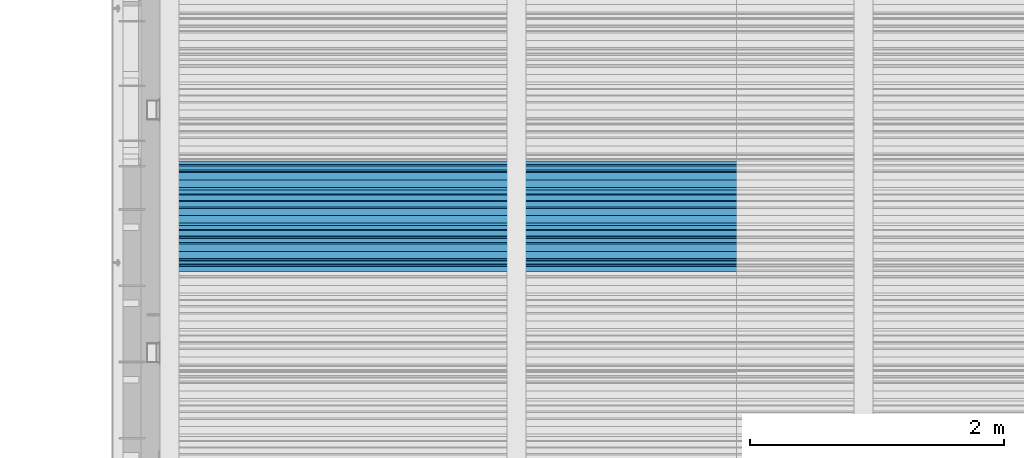
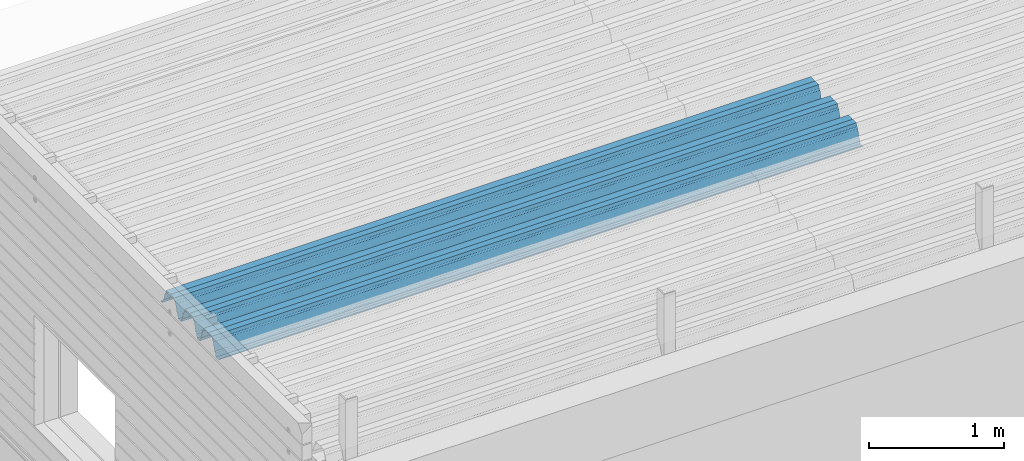
# One storey, part 27 of 153: 1 beam, 1 element without a shape of its own.
"""IFC2X3 building model written with IfcOpenShell, lengths in millimetres."""

from ifc_helpers import new_model, si_unit, frame, origin_with_axes, place, context, subcontext, project, spatial, faceted_brep, material, type_object, element, aggregate, save


model = new_model("IFC2X3")

# Units and contexts
model_context = context("Model", 3, precision=1e-05, world=origin_with_axes())
body_context = subcontext(model_context, "Body", "Model", "MODEL_VIEW")
ifc_project = project(units=[si_unit("LENGTHUNIT", "METRE", prefix="MILLI"), si_unit("AREAUNIT", "SQUARE_METRE"), si_unit("VOLUMEUNIT", "CUBIC_METRE"), si_unit("MASSUNIT", "GRAM", prefix="KILO"), si_unit("TIMEUNIT", "SECOND"), si_unit("PLANEANGLEUNIT", "RADIAN"), si_unit("SOLIDANGLEUNIT", "STERADIAN"), si_unit("THERMODYNAMICTEMPERATUREUNIT", "DEGREE_CELSIUS"), si_unit("LUMINOUSINTENSITYUNIT", "LUMEN")], contexts=[model_context])

# Site, building, storey
site_placement = place(None, origin_with_axes())
site = spatial("IfcSite", under=ifc_project, at=site_placement, CompositionType="ELEMENT")
building_placement = place(site_placement, origin_with_axes())
building = spatial("IfcBuilding", under=site, at=building_placement, CompositionType="ELEMENT")
storey_placement = place(building_placement, origin_with_axes())
storey = spatial("IfcBuildingStorey", under=building, at=storey_placement, Name="8", CompositionType="ELEMENT", Elevation=0.0)

# Assembly, beam
assembly_placement = place(storey_placement, origin_with_axes())
assembly = element("IfcElementAssembly", 1, at=assembly_placement, inside=storey, Name="Steel Assembly", AssemblyPlace="NOTDEFINED", PredefinedType="RIGID_FRAME")
ifc_material = material(Name="STEEL/S355J2")
beam_type = type_object("IfcBeamType", Name="W", PredefinedType="NOTDEFINED")
beam_placement = place(assembly_placement, frame((13534.9999999929, 17045.079381851, 105770.648873187), z_axis=(0.0, -0.0124990270013869, 0.999921884110963), x_axis=(-1.0, 3.00000001838171e-08, 0.0)))
beam = element("IfcBeam", 2, at=beam_placement, type_object=beam_type, material=ifc_material, ObjectType="W", context=body_context, shape_type="Brep", body=[
    faceted_brep([(0.0, -412.839996337891, -77.0100021362159), (0.0, -409.160003662109, -77.0100021362014), (5530.0, -409.160003662109, -77.0100021362014), (5530.0, -412.839996337891, -77.0100021362159), (0.0, -408.070007324222, -73.4800033569045), (5530.0, -408.070007324222, -73.4800033569045), (0.0, -400.339996337894, -48.0600013732619), (5530.0, -400.339996337894, -48.0600013732619), (0.0, -399.459991455082, -46.5600013732619), (5530.0, -399.459991455082, -46.5600013732619), (0.0, -390.329986572269, -36.5499992370314), (5530.0, -390.329986572269, -36.5499992370314), (0.0, -389.19000244141, -34.6300010680861), (5530.0, -389.19000244141, -34.6300010680861), (0.0, -367.820007324222, 35.3400001526024), (5530.0, -367.820007324222, 35.3400001526024), (0.0, -366.989990234379, 36.8499984741502), (5530.0, -366.989990234379, 36.8499984741502), (0.0, -357.809997558597, 46.8600006103807), (5530.0, -357.809997558597, 46.8600006103807), (0.0, -356.720001220707, 48.7700004577782), (5530.0, -356.720001220707, 48.7700004577782), (0.0, -349.309997558594, 73.1500015258935), (5530.0, -349.309997558594, 73.1500015258935), (0.0, -347.850006103516, 75.2300033569481), (5530.0, -347.850006103516, 75.2300033569481), (0.0, -345.470001220707, 76.010002136245), (5530.0, -345.470001220707, 76.010002136245), (0.0, -305.480010986332, 76.010002136245), (5530.0, -305.480010986332, 76.010002136245), (0.0, -304.279998779301, 75.8000030517578), (5530.0, -304.279998779301, 75.8000030517578), (0.0, -291.679992675785, 71.6999969482567), (5530.0, -291.679992675785, 71.6999969482567), (0.0, -290.179992675789, 71.2300033569481), (5530.0, -290.179992675789, 71.2300033569481), (0.0, -288.720001220707, 71.6999969482567), (5530.0, -288.720001220707, 71.6999969482567), (0.0, -276.119995117191, 75.8000030517869), (5530.0, -276.119995117191, 75.8000030517869), (0.0, -274.929992675785, 76.010002136245), (5530.0, -274.929992675785, 76.010002136245), (0.0, -234.94000244141, 76.010002136245), (5530.0, -234.94000244141, 76.010002136245), (0.0, -232.550003051758, 75.2300033569627), (5530.0, -232.550003051758, 75.2300033569627), (0.0, -231.100006103519, 73.1500015258935), (5530.0, -231.100006103519, 73.1500015258935), (0.0, -223.679992675785, 48.7700004577782), (5530.0, -223.679992675785, 48.7700004577782), (0.0, -222.589996337894, 46.8600006103661), (5530.0, -222.589996337894, 46.8600006103661), (0.0, -213.410003662113, 36.8499984741502), (5530.0, -213.410003662113, 36.8499984741502), (0.0, -212.529998779301, 35.3400001526024), (5530.0, -212.529998779301, 35.3400001526024), (0.0, -191.160003662109, -34.6300010681007), (5530.0, -191.160003662109, -34.6300010681007), (0.0, -190.070007324222, -36.5499992370605), (5530.0, -190.070007324222, -36.5499992370605), (0.0, -180.940002441406, -46.560001373291), (5530.0, -180.940002441406, -46.560001373291), (0.0, -180.059997558597, -48.0600013732619), (5530.0, -180.059997558597, -48.0600013732619), (0.0, -172.330001831055, -73.480003356919), (5530.0, -172.330001831055, -73.480003356919), (0.0, -171.240005493168, -77.0100021362159), (5530.0, -171.240005493168, -77.0100021362159), (0.0, -129.330001831062, -77.0100021362014), (5530.0, -129.330001831062, -77.0100021362014), (0.0, -128.300003051761, -73.480003356919), (5530.0, -128.300003051761, -73.480003356919), (0.0, -120.51999664307, -48.0600013732765), (5530.0, -120.51999664307, -48.0600013732765), (0.0, -119.629997253418, -46.5600013732765), (5530.0, -119.629997253418, -46.5600013732765), (0.0, -110.500000000004, -36.5499992370314), (5530.0, -110.500000000004, -36.5499992370314), (0.0, -109.419998168949, -34.6300010680861), (5530.0, -109.419998168949, -34.6300010680861), (0.0, -88.0500030517615, 35.3400001526024), (5530.0, -88.0500030517615, 35.3400001526024), (0.0, -87.160003662113, 36.8499984741356), (5530.0, -87.160003662113, 36.8499984741356), (0.0, -78.0400009155273, 46.8600006103807), (5530.0, -78.0400009155273, 46.8600006103807), (0.0, -76.8899993896557, 48.7700004577782), (5530.0, -76.8899993896557, 48.7700004577782), (0.0, -69.4800033569336, 73.1500015258935), (5530.0, -69.4800033569336, 73.1500015258935), (0.0, -68.0299987793042, 75.2300033569336), (5530.0, -68.0299987793042, 75.2300033569336), (0.0, -65.6399993896521, 76.010002136245), (5530.0, -65.6399993896521, 76.010002136245), (0.0, -25.6499996185375, 76.0100021362596), (5530.0, -25.6499996185375, 76.0100021362596), (0.0, -24.5100002288891, 75.8000030517724), (5530.0, -24.5100002288891, 75.8000030517724), (0.0, -11.8500003814697, 71.6999969482567), (5530.0, -11.8500003814697, 71.6999969482567), (0.0, -10.3999996185339, 71.2300033569481), (5530.0, -10.3999996185339, 71.2300033569481), (0.0, -8.89999961853391, 71.6999969482567), (5530.0, -8.89999961853391, 71.6999969482567), (0.0, 3.71000003814333, 75.8000030517724), (5530.0, 3.71000003814333, 75.8000030517724), (0.0, 4.90000009536379, 76.0100021362596), (5530.0, 4.90000009536379, 76.0100021362596), (0.0, 44.8899993896484, 76.010002136245), (5530.0, 44.8899993896484, 76.010002136245), (0.0, 47.2799987792932, 75.2300033569481), (5530.0, 47.2799987792932, 75.2300033569481), (0.0, 48.6800003051721, 73.1500015258935), (5530.0, 48.6800003051721, 73.1500015258935), (0.0, 56.1500015258753, 48.7700004577782), (5530.0, 56.1500015258753, 48.7700004577782), (0.0, 57.2400016784632, 46.8600006103807), (5530.0, 57.2400016784632, 46.8600006103807), (0.0, 66.3700027465784, 36.8499984741211), (5530.0, 66.3700027465784, 36.8499984741211), (0.0, 67.2499999999964, 35.3400001526024), (5530.0, 67.2499999999964, 35.3400001526024), (0.0, 88.6200027465748, -34.6300010681007), (5530.0, 88.6200027465748, -34.6300010681007), (0.0, 89.709999084469, -36.549999237046), (5530.0, 89.709999084469, -36.549999237046), (0.0, 98.8899993896412, -46.5600013732765), (5530.0, 98.8899993896412, -46.5600013732765), (0.0, 99.7699966430628, -48.0600013732765), (5530.0, 99.7699966430628, -48.0600013732765), (0.0, 107.499999999996, -73.4800033569336), (5530.0, 107.499999999996, -73.4800033569336), (0.0, 108.589996337887, -77.0100021362014), (5530.0, 108.589996337887, -77.0100021362014), (0.0, 112.269996643063, -77.0100021362159), (5530.0, 112.269996643063, -77.0100021362159), (0.0, 146.759994506836, -77.0100021362159), (5530.0, 146.759994506836, -77.0100021362159), (0.0, 150.440002441403, -77.0100021362159), (5530.0, 150.440002441403, -77.0100021362159), (0.0, 151.529998779297, -73.480003356919), (5530.0, 151.529998779297, -73.480003356919), (0.0, 159.30999755859, -48.0600013732765), (5530.0, 159.30999755859, -48.0600013732765), (0.0, 160.190002441406, -46.5600013732619), (5530.0, 160.190002441406, -46.5600013732619), (0.0, 169.320007324215, -36.549999237046), (5530.0, 169.320007324215, -36.549999237046), (0.0, 170.410003662106, -34.6300010680861), (5530.0, 170.410003662106, -34.6300010680861), (0.0, 191.779998779293, 35.3400001526024), (5530.0, 191.779998779293, 35.3400001526024), (0.0, 192.660003662109, 36.8499984741502), (5530.0, 192.660003662109, 36.8499984741502), (0.0, 201.789993286129, 46.8600006103661), (5530.0, 201.789993286129, 46.8600006103661), (0.0, 202.880004882809, 48.7700004577637), (5530.0, 202.880004882809, 48.7700004577637), (0.0, 210.350006103512, 73.150001525908), (5530.0, 210.350006103512, 73.150001525908), (0.0, 211.800003051754, 75.2300033569481), (5530.0, 211.800003051754, 75.2300033569481), (0.0, 214.190002441406, 76.010002136245), (5530.0, 214.190002441406, 76.010002136245), (0.0, 254.179992675778, 76.010002136245), (5530.0, 254.179992675778, 76.010002136245), (0.0, 255.320007324215, 75.8000030517869), (5530.0, 255.320007324215, 75.8000030517869), (0.0, 267.980010986324, 71.6999969482713), (5530.0, 267.980010986324, 71.6999969482713), (0.0, 269.429992675778, 71.2300033569481), (5530.0, 269.429992675778, 71.2300033569481), (0.0, 270.880004882809, 71.6999969482567), (5530.0, 270.880004882809, 71.6999969482567), (0.0, 283.540008544918, 75.8000030517869), (5530.0, 283.540008544918, 75.8000030517869), (0.0, 284.679992675778, 76.010002136245), (5530.0, 284.679992675778, 76.010002136245), (0.0, 324.670013427731, 76.010002136245), (5530.0, 324.670013427731, 76.010002136245), (0.0, 327.049987792969, 75.2300033569627), (5530.0, 327.049987792969, 75.2300033569627), (0.0, 328.510009765625, 73.1500015258789), (5530.0, 328.510009765625, 73.1500015258789), (0.0, 335.980010986324, 48.7700004577782), (5530.0, 335.980010986324, 48.7700004577782), (0.0, 337.05999755859, 46.8600006103661), (5530.0, 337.05999755859, 46.8600006103661), (0.0, 346.190002441399, 36.8499984741356), (5530.0, 346.190002441399, 36.8499984741356), (0.0, 347.079986572266, 35.3400001526024), (5530.0, 347.079986572266, 35.3400001526024), (0.0, 368.450012207028, -34.6300010680861), (5530.0, 368.450012207028, -34.6300010680861), (0.0, 369.529998779293, -36.5499992370314), (5530.0, 369.529998779293, -36.5499992370314), (0.0, 378.660003662106, -46.5600013732619), (5530.0, 378.660003662106, -46.5600013732619), (0.0, 379.540008544918, -48.0600013732619), (5530.0, 379.540008544918, -48.0600013732619), (0.0, 387.329986572262, -73.480003356919), (5530.0, 387.329986572262, -73.480003356919), (0.0, 388.410003662109, -77.0100021362159), (5530.0, 388.410003662109, -77.0100021362159), (0.0, 392.100006103512, -77.0100021362159), (5530.0, 392.100006103512, -77.0100021362159), (0.0, 426.589996337887, -77.0100021362159), (5530.0, 426.589996337887, -77.0100021362159), (0.0, 430.269989013668, -77.0100021362159), (5530.0, 430.269989013668, -77.0100021362159), (0.0, 431.359985351559, -73.4800033569045), (5530.0, 431.359985351559, -73.4800033569045), (0.0, 433.179992675778, -67.5699996948097), (5530.0, 433.179992675778, -67.5699996948097), (0.0, 432.220001220699, -67.2699966430373), (5530.0, 432.220001220699, -67.2699966430373), (0.0, 430.410003662106, -73.1800003051612), (5530.0, 430.410003662106, -73.1800003051612), (0.0, 429.529998779293, -76.0100021362159), (5530.0, 429.529998779293, -76.0100021362159), (0.0, 426.589996337891, -76.0100021362159), (5530.0, 426.589996337891, -76.0100021362159), (0.0, 392.100006103512, -76.0100021362159), (5530.0, 392.100006103512, -76.0100021362159), (0.0, 389.149993896481, -76.0100021362014), (5530.0, 389.149993896481, -76.0100021362014), (0.0, 388.279998779293, -73.1800003051467), (5530.0, 388.279998779293, -73.1800003051467), (0.0, 380.470001220699, -47.659999847383), (5530.0, 380.470001220699, -47.659999847383), (0.0, 379.470001220699, -45.9599990844436), (5530.0, 379.470001220699, -45.9599990844436), (0.0, 370.350006103512, -35.9599990844581), (5530.0, 370.350006103512, -35.9599990844581), (0.0, 369.369995117184, -34.2299995422218), (5530.0, 369.369995117184, -34.2299995422218), (0.0, 347.999999999996, 35.7500000000146), (5530.0, 347.999999999996, 35.7500000000146), (0.0, 346.999999999996, 37.4399986267235), (5530.0, 346.999999999996, 37.4399986267235), (0.0, 337.880004882809, 47.450000762954), (5530.0, 337.880004882809, 47.450000762954), (0.0, 336.899993896481, 49.1699981689453), (5530.0, 336.899993896481, 49.1699981689453), (0.0, 329.420013427731, 73.5999984741356), (5530.0, 329.420013427731, 73.5999984741356), (0.0, 327.679992675781, 76.0699996948533), (5530.0, 327.679992675781, 76.0699996948533), (0.0, 324.829986572262, 77.010002136245), (5530.0, 324.829986572262, 77.010002136245), (0.0, 284.589996337887, 77.010002136245), (5530.0, 284.589996337887, 77.010002136245), (0.0, 283.290008544922, 76.769996643081), (5530.0, 283.290008544922, 76.769996643081), (0.0, 270.570007324215, 72.6500015258935), (5530.0, 270.570007324215, 72.6500015258935), (0.0, 269.429992675781, 72.2799987793114), (5530.0, 269.429992675781, 72.2799987793114), (0.0, 268.279998779293, 72.650001525908), (5530.0, 268.279998779293, 72.650001525908), (0.0, 255.570007324219, 76.769996643081), (5530.0, 255.570007324219, 76.769996643081), (0.0, 254.270004272461, 77.0100021362596), (5530.0, 254.270004272461, 77.0100021362596), (0.0, 214.029998779293, 77.0100021362596), (5530.0, 214.029998779293, 77.0100021362596), (0.0, 211.179992675781, 76.0699996948388), (5530.0, 211.179992675781, 76.0699996948388), (0.0, 209.440002441403, 73.5999984741356), (5530.0, 209.440002441403, 73.5999984741356), (0.0, 201.960006713864, 49.1699981689599), (5530.0, 201.960006713864, 49.1699981689599), (0.0, 200.979995727532, 47.450000762954), (5530.0, 200.979995727532, 47.450000762954), (0.0, 191.850006103508, 37.4399986267235), (5530.0, 191.850006103508, 37.4399986267235), (0.0, 190.860000610352, 35.7500000000146), (5530.0, 190.860000610352, 35.7500000000146), (0.0, 169.49000549316, -34.2299995422218), (5530.0, 169.49000549316, -34.2299995422218), (0.0, 168.509994506832, -35.9599990844581), (5530.0, 168.509994506832, -35.9599990844581), (0.0, 159.380004882805, -45.9599990844436), (5530.0, 159.380004882805, -45.9599990844436), (0.0, 158.389999389645, -47.6599998473976), (5530.0, 158.389999389645, -47.6599998473976), (0.0, 150.580001831051, -73.1800003051612), (5530.0, 150.580001831051, -73.1800003051612), (0.0, 149.710006713864, -76.0100021362159), (5530.0, 149.710006713864, -76.0100021362159), (0.0, 146.759994506836, -76.0100021362159), (5530.0, 146.759994506836, -76.0100021362159), (0.0, 112.269996643063, -76.0100021362159), (5530.0, 112.269996643063, -76.0100021362159), (0.0, 109.319999694821, -76.0100021362159), (5530.0, 109.319999694821, -76.0100021362159), (0.0, 108.449996948239, -73.1900024413917), (5530.0, 108.449996948239, -73.1900024413917), (0.0, 100.690002441406, -47.659999847383), (5530.0, 100.690002441406, -47.659999847383), (0.0, 99.6999969482386, -45.9599990844581), (5530.0, 99.6999969482386, -45.9599990844581), (0.0, 90.5199966430664, -35.9599990844581), (5530.0, 90.5199966430664, -35.9599990844581), (0.0, 89.5400009155273, -34.2299995422218), (5530.0, 89.5400009155273, -34.2299995422218), (0.0, 68.1699981689417, 35.7500000000146), (5530.0, 68.1699981689417, 35.7500000000146), (0.0, 67.1699981689417, 37.4399986267235), (5530.0, 67.1699981689417, 37.4399986267235), (0.0, 58.0499992370569, 47.4500007629686), (5530.0, 58.0499992370569, 47.4500007629686), (0.0, 57.0699996948206, 49.1699981689599), (5530.0, 57.0699996948206, 49.1699981689599), (0.0, 49.5900001525843, 73.5899963379052), (5530.0, 49.5900001525843, 73.5899963379052), (0.0, 47.9099998474085, 76.0699996948388), (5530.0, 47.9099998474085, 76.0699996948388), (0.0, 45.0499992370569, 77.010002136245), (5530.0, 45.0499992370569, 77.010002136245), (0.0, 4.82000017165774, 77.010002136245), (5530.0, 4.82000017165774, 77.010002136245), (0.0, 3.47000002860659, 76.7699966430955), (5530.0, 3.47000002860659, 76.7699966430955), (0.0, -9.19999980926514, 72.6500015258935), (5530.0, -9.19999980926514, 72.6500015258935), (0.0, -10.3900003433264, 72.2799987792969), (5530.0, -10.3900003433264, 72.2799987792969), (0.0, -11.5399999618567, 72.6500015258935), (5530.0, -11.5399999618567, 72.6500015258935), (0.0, -24.2600002288855, 76.769996643081), (5530.0, -24.2600002288855, 76.769996643081), (0.0, -25.559999465946, 77.0100021362596), (5530.0, -25.559999465946, 77.0100021362596), (0.0, -65.8000030517615, 77.0100021362596), (5530.0, -65.8000030517615, 77.0100021362596), (0.0, -68.6500015258862, 76.0699996948533), (5530.0, -68.6500015258862, 76.0699996948533), (0.0, -70.3899993896521, 73.5999984741356), (5530.0, -70.3899993896521, 73.5999984741356), (0.0, -77.8199996948242, 49.1800003051903), (5530.0, -77.8199996948242, 49.1800003051903), (0.0, -78.8399963378943, 47.450000762954), (5530.0, -78.8399963378943, 47.450000762954), (0.0, -87.9700012207031, 37.4399986267235), (5530.0, -87.9700012207031, 37.4399986267235), (0.0, -88.9700012207068, 35.7500000000146), (5530.0, -88.9700012207068, 35.7500000000146), (0.0, -110.339996337894, -34.2299995422218), (5530.0, -110.339996337894, -34.2299995422218), (0.0, -111.319999694828, -35.9599990844581), (5530.0, -111.319999694828, -35.9599990844581), (0.0, -120.440002441406, -45.9599990844436), (5530.0, -120.440002441406, -45.9599990844436), (0.0, -121.44000244141, -47.6599998473976), (5530.0, -121.44000244141, -47.6599998473976), (0.0, -129.250000000004, -73.1900024413771), (5530.0, -129.250000000004, -73.1900024413771), (0.0, -130.080001831062, -76.0100021362159), (5530.0, -130.080001831062, -76.0100021362159), (0.0, -170.5, -76.0100021362014), (5530.0, -170.5, -76.0100021362014), (0.0, -171.380004882816, -73.1900024413917), (5530.0, -171.380004882816, -73.1900024413917), (0.0, -179.139999389652, -47.6599998473976), (5530.0, -179.139999389652, -47.6599998473976), (0.0, -180.130004882816, -45.9599990844581), (5530.0, -180.130004882816, -45.9599990844581), (0.0, -189.259994506836, -35.9599990844581), (5530.0, -189.259994506836, -35.9599990844581), (0.0, -190.240005493168, -34.2299995422218), (5530.0, -190.240005493168, -34.2299995422218), (0.0, -211.610000610355, 35.7500000000146), (5530.0, -211.610000610355, 35.7500000000146), (0.0, -212.600006103519, 37.4399986267381), (5530.0, -212.600006103519, 37.4399986267381), (0.0, -221.779998779301, 47.450000762954), (5530.0, -221.779998779301, 47.450000762954), (0.0, -222.75999450684, 49.1699981689599), (5530.0, -222.75999450684, 49.1699981689599), (0.0, -230.190002441406, 73.5999984741356), (5530.0, -230.190002441406, 73.5999984741356), (0.0, -231.919998168945, 76.0699996948388), (5530.0, -231.919998168945, 76.0699996948388), (0.0, -234.779998779301, 77.010002136245), (5530.0, -234.779998779301, 77.010002136245), (0.0, -275.010009765629, 77.010002136245), (5530.0, -275.010009765629, 77.010002136245), (0.0, -276.359985351563, 76.769996643081), (5530.0, -276.359985351563, 76.769996643081), (0.0, -289.029998779297, 72.6500015258789), (5530.0, -289.029998779297, 72.6500015258789), (0.0, -290.179992675785, 72.2799987793114), (5530.0, -290.179992675785, 72.2799987793114), (0.0, -291.380004882816, 72.650001525908), (5530.0, -291.380004882816, 72.650001525908), (0.0, -304.040008544926, 76.769996643081), (5530.0, -304.040008544926, 76.769996643081), (0.0, -305.390014648441, 77.010002136245), (5530.0, -305.390014648441, 77.010002136245), (0.0, -345.63000488282, 77.0100021362596), (5530.0, -345.63000488282, 77.0100021362596), (0.0, -348.480010986332, 76.0699996948388), (5530.0, -348.480010986332, 76.0699996948388), (0.0, -350.220001220707, 73.5999984741356), (5530.0, -350.220001220707, 73.5999984741356), (0.0, -357.649993896492, 49.1699981689599), (5530.0, -357.649993896492, 49.1699981689599), (0.0, -358.63000488282, 47.450000762954), (5530.0, -358.63000488282, 47.450000762954), (0.0, -367.809997558594, 37.4300003051903), (5530.0, -367.809997558594, 37.4300003051903), (0.0, -368.750000000004, 35.7299995422654), (5530.0, -368.750000000004, 35.7299995422654), (0.0, -390.109985351566, -34.2200012207031), (5530.0, -390.109985351566, -34.2200012207031), (0.0, -391.140014648441, -35.9500007629249), (5530.0, -391.140014648441, -35.9500007629249), (0.0, -400.269989013676, -45.9599990844436), (5530.0, -400.269989013676, -45.9599990844436), (0.0, -401.269989013672, -47.6599998473976), (5530.0, -401.269989013672, -47.6599998473976), (0.0, -409.029998779297, -73.1900024413917), (5530.0, -409.029998779297, -73.1900024413917), (0.0, -409.899993896488, -76.0100021362159), (5530.0, -409.899993896488, -76.0100021362159), (0.0, -412.839996337891, -76.0100021362159), (5530.0, -412.839996337891, -76.0100021362159), (0.0, -433.179992675785, -76.0100021362159), (5530.0, -433.179992675785, -76.0100021362159), (0.0, -433.179992675785, -77.0100021362159), (5530.0, -433.179992675785, -77.0100021362159)], [[[0, 1, 2, 3]], [[1, 4, 5, 2]], [[4, 6, 7, 5]], [[6, 8, 9, 7]], [[8, 10, 11, 9]], [[10, 12, 13, 11]], [[12, 14, 15, 13]], [[14, 16, 17, 15]], [[16, 18, 19, 17]], [[18, 20, 21, 19]], [[20, 22, 23, 21]], [[22, 24, 25, 23]], [[24, 26, 27, 25]], [[26, 28, 29, 27]], [[28, 30, 31, 29]], [[30, 32, 33, 31]], [[32, 34, 35, 33]], [[34, 36, 37, 35]], [[36, 38, 39, 37]], [[38, 40, 41, 39]], [[40, 42, 43, 41]], [[42, 44, 45, 43]], [[44, 46, 47, 45]], [[46, 48, 49, 47]], [[48, 50, 51, 49]], [[50, 52, 53, 51]], [[52, 54, 55, 53]], [[54, 56, 57, 55]], [[56, 58, 59, 57]], [[58, 60, 61, 59]], [[60, 62, 63, 61]], [[62, 64, 65, 63]], [[64, 66, 67, 65]], [[66, 68, 69, 67]], [[68, 70, 71, 69]], [[70, 72, 73, 71]], [[72, 74, 75, 73]], [[74, 76, 77, 75]], [[76, 78, 79, 77]], [[78, 80, 81, 79]], [[80, 82, 83, 81]], [[82, 84, 85, 83]], [[84, 86, 87, 85]], [[86, 88, 89, 87]], [[88, 90, 91, 89]], [[90, 92, 93, 91]], [[92, 94, 95, 93]], [[94, 96, 97, 95]], [[96, 98, 99, 97]], [[98, 100, 101, 99]], [[100, 102, 103, 101]], [[102, 104, 105, 103]], [[104, 106, 107, 105]], [[106, 108, 109, 107]], [[108, 110, 111, 109]], [[110, 112, 113, 111]], [[112, 114, 115, 113]], [[114, 116, 117, 115]], [[116, 118, 119, 117]], [[118, 120, 121, 119]], [[120, 122, 123, 121]], [[122, 124, 125, 123]], [[124, 126, 127, 125]], [[126, 128, 129, 127]], [[128, 130, 131, 129]], [[130, 132, 133, 131]], [[132, 134, 135, 133]], [[134, 136, 137, 135]], [[136, 138, 139, 137]], [[138, 140, 141, 139]], [[140, 142, 143, 141]], [[142, 144, 145, 143]], [[144, 146, 147, 145]], [[146, 148, 149, 147]], [[148, 150, 151, 149]], [[150, 152, 153, 151]], [[152, 154, 155, 153]], [[154, 156, 157, 155]], [[156, 158, 159, 157]], [[158, 160, 161, 159]], [[160, 162, 163, 161]], [[162, 164, 165, 163]], [[164, 166, 167, 165]], [[166, 168, 169, 167]], [[168, 170, 171, 169]], [[170, 172, 173, 171]], [[172, 174, 175, 173]], [[174, 176, 177, 175]], [[176, 178, 179, 177]], [[178, 180, 181, 179]], [[180, 182, 183, 181]], [[182, 184, 185, 183]], [[184, 186, 187, 185]], [[186, 188, 189, 187]], [[188, 190, 191, 189]], [[190, 192, 193, 191]], [[192, 194, 195, 193]], [[194, 196, 197, 195]], [[196, 198, 199, 197]], [[198, 200, 201, 199]], [[200, 202, 203, 201]], [[202, 204, 205, 203]], [[204, 206, 207, 205]], [[206, 208, 209, 207]], [[208, 210, 211, 209]], [[210, 212, 213, 211]], [[212, 214, 215, 213]], [[214, 216, 217, 215]], [[216, 218, 219, 217]], [[218, 220, 221, 219]], [[220, 222, 223, 221]], [[222, 224, 225, 223]], [[224, 226, 227, 225]], [[226, 228, 229, 227]], [[228, 230, 231, 229]], [[230, 232, 233, 231]], [[232, 234, 235, 233]], [[234, 236, 237, 235]], [[236, 238, 239, 237]], [[238, 240, 241, 239]], [[240, 242, 243, 241]], [[242, 244, 245, 243]], [[244, 246, 247, 245]], [[246, 248, 249, 247]], [[248, 250, 251, 249]], [[250, 252, 253, 251]], [[252, 254, 255, 253]], [[254, 256, 257, 255]], [[256, 258, 259, 257]], [[258, 260, 261, 259]], [[260, 262, 263, 261]], [[262, 264, 265, 263]], [[264, 266, 267, 265]], [[266, 268, 269, 267]], [[268, 270, 271, 269]], [[270, 272, 273, 271]], [[272, 274, 275, 273]], [[274, 276, 277, 275]], [[276, 278, 279, 277]], [[278, 280, 281, 279]], [[280, 282, 283, 281]], [[282, 284, 285, 283]], [[284, 286, 287, 285]], [[286, 288, 289, 287]], [[288, 290, 291, 289]], [[290, 292, 293, 291]], [[292, 294, 295, 293]], [[294, 296, 297, 295]], [[296, 298, 299, 297]], [[298, 300, 301, 299]], [[300, 302, 303, 301]], [[302, 304, 305, 303]], [[304, 306, 307, 305]], [[306, 308, 309, 307]], [[308, 310, 311, 309]], [[310, 312, 313, 311]], [[312, 314, 315, 313]], [[314, 316, 317, 315]], [[316, 318, 319, 317]], [[318, 320, 321, 319]], [[320, 322, 323, 321]], [[322, 324, 325, 323]], [[324, 326, 327, 325]], [[326, 328, 329, 327]], [[328, 330, 331, 329]], [[330, 332, 333, 331]], [[332, 334, 335, 333]], [[334, 336, 337, 335]], [[336, 338, 339, 337]], [[338, 340, 341, 339]], [[340, 342, 343, 341]], [[342, 344, 345, 343]], [[344, 346, 347, 345]], [[346, 348, 349, 347]], [[348, 350, 351, 349]], [[350, 352, 353, 351]], [[352, 354, 355, 353]], [[354, 356, 357, 355]], [[356, 358, 359, 357]], [[358, 360, 361, 359]], [[360, 362, 363, 361]], [[362, 364, 365, 363]], [[364, 366, 367, 365]], [[366, 368, 369, 367]], [[368, 370, 371, 369]], [[370, 372, 373, 371]], [[372, 374, 375, 373]], [[374, 376, 377, 375]], [[376, 378, 379, 377]], [[378, 380, 381, 379]], [[380, 382, 383, 381]], [[382, 384, 385, 383]], [[384, 386, 387, 385]], [[386, 388, 389, 387]], [[388, 390, 391, 389]], [[390, 392, 393, 391]], [[392, 394, 395, 393]], [[394, 396, 397, 395]], [[396, 398, 399, 397]], [[398, 400, 401, 399]], [[400, 402, 403, 401]], [[402, 404, 405, 403]], [[404, 406, 407, 405]], [[406, 408, 409, 407]], [[408, 410, 411, 409]], [[410, 412, 413, 411]], [[412, 414, 415, 413]], [[414, 416, 417, 415]], [[416, 418, 419, 417]], [[418, 420, 421, 419]], [[420, 422, 423, 421]], [[422, 424, 425, 423]], [[424, 426, 427, 425]], [[426, 428, 429, 427]], [[428, 430, 431, 429]], [[430, 0, 3, 431]], [[5, 7, 9, 11, 13, 15, 17, 19, 21, 23, 25, 27, 29, 31, 33, 35, 37, 39, 41, 43, 45, 47, 49, 51, 53, 55, 57, 59, 61, 63, 65, 67, 69, 71, 73, 75, 77, 79, 81, 83, 85, 87, 89, 91, 93, 95, 97, 99, 101, 103, 105, 107, 109, 111, 113, 115, 117, 119, 121, 123, 125, 127, 129, 131, 133, 135, 137, 139, 141, 143, 145, 147, 149, 151, 153, 155, 157, 159, 161, 163, 165, 167, 169, 171, 173, 175, 177, 179, 181, 183, 185, 187, 189, 191, 193, 195, 197, 199, 201, 203, 205, 207, 209, 211, 213, 215, 217, 219, 221, 223, 225, 227, 229, 231, 233, 235, 237, 239, 241, 243, 245, 247, 249, 251, 253, 255, 257, 259, 261, 263, 265, 267, 269, 271, 273, 275, 277, 279, 281, 283, 285, 287, 289, 291, 293, 295, 297, 299, 301, 303, 305, 307, 309, 311, 313, 315, 317, 319, 321, 323, 325, 327, 329, 331, 333, 335, 337, 339, 341, 343, 345, 347, 349, 351, 353, 355, 357, 359, 361, 363, 365, 367, 369, 371, 373, 375, 377, 379, 381, 383, 385, 387, 389, 391, 393, 395, 397, 399, 401, 403, 405, 407, 409, 411, 413, 415, 417, 419, 421, 423, 425, 427, 429, 431, 3, 2]], [[430, 428, 426, 424, 422, 420, 418, 416, 414, 412, 410, 408, 406, 404, 402, 400, 398, 396, 394, 392, 390, 388, 386, 384, 382, 380, 378, 376, 374, 372, 370, 368, 366, 364, 362, 360, 358, 356, 354, 352, 350, 348, 346, 344, 342, 340, 338, 336, 334, 332, 330, 328, 326, 324, 322, 320, 318, 316, 314, 312, 310, 308, 306, 304, 302, 300, 298, 296, 294, 292, 290, 288, 286, 284, 282, 280, 278, 276, 274, 272, 270, 268, 266, 264, 262, 260, 258, 256, 254, 252, 250, 248, 246, 244, 242, 240, 238, 236, 234, 232, 230, 228, 226, 224, 222, 220, 218, 216, 214, 212, 210, 208, 206, 204, 202, 200, 198, 196, 194, 192, 190, 188, 186, 184, 182, 180, 178, 176, 174, 172, 170, 168, 166, 164, 162, 160, 158, 156, 154, 152, 150, 148, 146, 144, 142, 140, 138, 136, 134, 132, 130, 128, 126, 124, 122, 120, 118, 116, 114, 112, 110, 108, 106, 104, 102, 100, 98, 96, 94, 92, 90, 88, 86, 84, 82, 80, 78, 76, 74, 72, 70, 68, 66, 64, 62, 60, 58, 56, 54, 52, 50, 48, 46, 44, 42, 40, 38, 36, 34, 32, 30, 28, 26, 24, 22, 20, 18, 16, 14, 12, 10, 8, 6, 4, 1, 0]]]),
])
aggregate(assembly, [beam])

save(model, "model.ifc")
